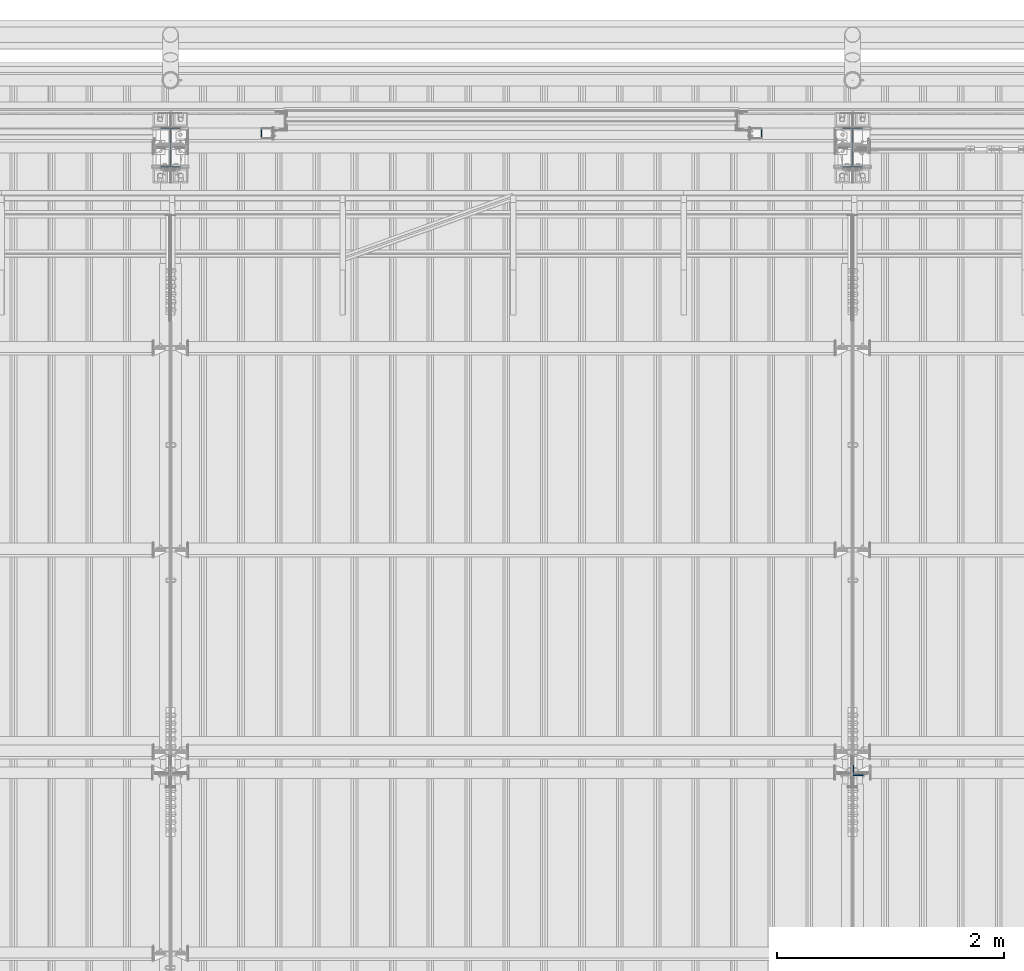
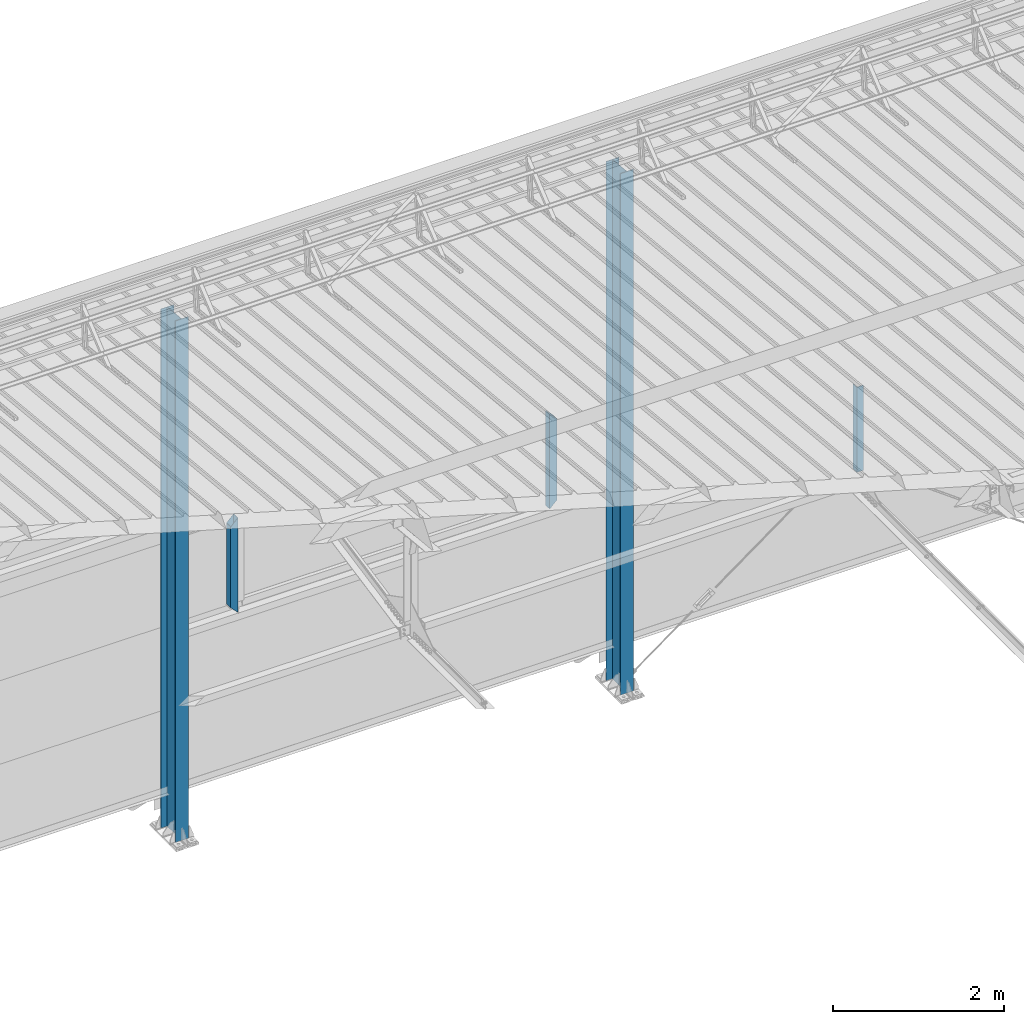
# One storey, part 232 of 709: 5 columns, 5 elements without a shape of their own.
"""IFC4 building model written with IfcOpenShell, lengths in millimetres."""

from ifc_helpers import new_model, si_unit, direction, frame, origin_with_axes, place, context, subcontext, project, spatial, polygons, material, element, aggregate, save


model = new_model("IFC4")

# Units and contexts
model_context = context("Model", 3, precision=0.2, world=origin_with_axes(), true_north=direction((0.0, 1.0)))
body_context = subcontext(model_context, "Body", "Model", "MODEL_VIEW")
ifc_project = project(units=[si_unit("LENGTHUNIT", "METRE", prefix="MILLI"), si_unit("AREAUNIT", "SQUARE_METRE"), si_unit("VOLUMEUNIT", "CUBIC_METRE"), si_unit("MASSUNIT", "GRAM", prefix="KILO"), si_unit("TIMEUNIT", "SECOND"), si_unit("PLANEANGLEUNIT", "RADIAN"), si_unit("SOLIDANGLEUNIT", "STERADIAN"), si_unit("THERMODYNAMICTEMPERATUREUNIT", "DEGREE_CELSIUS"), si_unit("LUMINOUSINTENSITYUNIT", "LUMEN")], contexts=[model_context])

# Site, building, storey
site_placement = place(None, origin_with_axes())
site = spatial("IfcSite", under=ifc_project, at=site_placement, CompositionType="ELEMENT")
building_placement = place(site_placement, origin_with_axes())
building = spatial("IfcBuilding", under=site, at=building_placement, Name="Undefined", CompositionType="ELEMENT")
storey_placement = place(building_placement, origin_with_axes())
storey = spatial("IfcBuildingStorey", under=building, at=storey_placement, Name="Undefined", CompositionType="ELEMENT", Elevation=0.0)

# Assembly, column
assembly_1_placement = place(storey_placement, frame((16000.0, 21827.0, -200.0), z_axis=(-1.0, 0.0, 0.0), x_axis=(0.0, 0.0, 1.0)))
assembly_1 = element("IfcElementAssembly", 1, at=assembly_1_placement, inside=storey)
ifc_material_1 = material(Name="C355-5", Category="STEEL")
column_1_placement = place(assembly_1_placement, origin_with_axes())
column_1 = element("IfcColumn", 2, at=column_1_placement, material=ifc_material_1, ObjectType="413", context=body_context, shape_type="Tessellation", body=[
    polygons([(25.0, -173.0, -87.0), (25.0, -164.0, -87.0), (7454.62297, -164.0, -87.0), (7455.52297, -173.0, -87.0), (25.0, -164.0, -3.0), (7454.62297, -164.0, -3.0), (25.0, 164.0, -3.0), (7421.82297, 164.0, -3.0), (25.0, 164.0, -87.0), (7421.82297, 164.0, -87.0), (25.0, 173.0, -87.0), (7420.92297, 173.0, -87.0), (25.0, 173.0, 87.0), (7420.92297, 173.0, 87.0), (25.0, 164.0, 87.0), (7421.82297, 164.0, 87.0), (25.0, 164.0, 3.0), (7421.82297, 164.0, 3.0), (25.0, -164.0, 3.0), (7454.62297, -164.0, 3.0), (25.0, -164.0, 87.0), (7454.62297, -164.0, 87.0), (25.0, -173.0, 87.0), (7455.52297, -173.0, 87.0)], [[[1, 2, 3, 4]], [[2, 5, 6, 3]], [[5, 7, 8, 6]], [[7, 9, 10, 8]], [[9, 11, 12, 10]], [[11, 13, 14, 12]], [[13, 15, 16, 14]], [[15, 17, 18, 16]], [[17, 19, 20, 18]], [[19, 21, 22, 20]], [[21, 23, 24, 22]], [[23, 1, 4, 24]], [[6, 8, 10, 12, 14, 16, 18, 20, 22, 24, 4, 3]], [[23, 21, 19, 17, 15, 13, 11, 9, 7, 5, 2, 1]]], closed=True),
])
aggregate(assembly_1, [column_1])

assembly_2_placement = place(storey_placement, frame((22051.0, 16347.7, 6024.30002), z_axis=(0.0, 1.0, 0.0), x_axis=(0.0, 0.0, 1.0)))
assembly_2 = element("IfcElementAssembly", 3, at=assembly_2_placement, inside=storey)
ifc_material_2 = material(Name="C345-5", Category="STEEL")
column_2_placement = place(assembly_2_placement, origin_with_axes())
column_2 = element("IfcColumn", 4, at=column_2_placement, material=ifc_material_2, ObjectType="436", context=body_context, shape_type="Tessellation", body=[
    polygons([(185.7, -45.0, -45.0), (185.7, 45.0, -45.0), (1399.4109, 45.0, -45.0), (1399.4109, -45.0, -45.0), (185.7, 45.0, -39.0), (1399.4109, 45.0, -39.0), (185.7, -39.0, -39.0), (1399.4109, -39.0, -39.0), (185.7, -39.0, 45.0), (1399.4109, -39.0, 45.0), (185.7, -45.0, 45.0), (1399.4109, -45.0, 45.0)], [[[1, 2, 3, 4]], [[2, 5, 6, 3]], [[5, 7, 8, 6]], [[7, 9, 10, 8]], [[9, 11, 12, 10]], [[11, 1, 4, 12]], [[6, 8, 10, 12, 4, 3]], [[11, 9, 7, 5, 2, 1]]], closed=True),
])
aggregate(assembly_2, [column_2])

assembly_3_placement = place(storey_placement, frame((22000.0, 21827.0, -200.0), z_axis=(-1.0, 0.0, 0.0), x_axis=(0.0, 0.0, 1.0)))
assembly_3 = element("IfcElementAssembly", 5, at=assembly_3_placement, inside=storey)
column_3_placement = place(assembly_3_placement, origin_with_axes())
column_3 = element("IfcColumn", 6, at=column_3_placement, material=ifc_material_1, ObjectType="413", context=body_context, shape_type="Tessellation", body=[
    polygons([(25.0, -173.0, -87.0), (25.0, -164.0, -87.0), (7454.62297, -164.0, -87.0), (7455.52297, -173.0, -87.0), (25.0, -164.0, -3.0), (7454.62297, -164.0, -3.0), (25.0, 164.0, -3.0), (7421.82297, 164.0, -3.0), (25.0, 164.0, -87.0), (7421.82297, 164.0, -87.0), (25.0, 173.0, -87.0), (7420.92297, 173.0, -87.0), (25.0, 173.0, 87.0), (7420.92297, 173.0, 87.0), (25.0, 164.0, 87.0), (7421.82297, 164.0, 87.0), (25.0, 164.0, 3.0), (7421.82297, 164.0, 3.0), (25.0, -164.0, 3.0), (7454.62297, -164.0, 3.0), (25.0, -164.0, 87.0), (7454.62297, -164.0, 87.0), (25.0, -173.0, 87.0), (7455.52297, -173.0, 87.0)], [[[1, 2, 3, 4]], [[2, 5, 6, 3]], [[5, 7, 8, 6]], [[7, 9, 10, 8]], [[9, 11, 12, 10]], [[11, 13, 14, 12]], [[13, 15, 16, 14]], [[15, 17, 18, 16]], [[17, 19, 20, 18]], [[19, 21, 22, 20]], [[21, 23, 24, 22]], [[23, 1, 4, 24]], [[6, 8, 10, 12, 14, 16, 18, 20, 22, 24, 4, 3]], [[23, 21, 19, 17, 15, 13, 11, 9, 7, 5, 2, 1]]], closed=True),
])
aggregate(assembly_3, [column_3])

assembly_4_placement = place(storey_placement, frame((21150.0, 21950.0, 2600.0), z_axis=(-1.0, 0.0, 0.0), x_axis=(0.0, 0.0, 1.0)))
assembly_4 = element("IfcElementAssembly", 7, at=assembly_4_placement, inside=storey)
ifc_material_3 = material(Name="C355", Category="STEEL")
column_4_placement = place(assembly_4_placement, origin_with_axes())
column_4 = element("IfcColumn", 8, at=column_4_placement, material=ifc_material_3, ObjectType="493", context=body_context, shape_type="Tessellation", body=[
    polygons([(10.0, -50.0, 50.0), (110.0, -50.0, -50.0), (1260.0, -50.0, -50.0), (1360.0, -50.0, 50.0), (10.0, 50.0, 50.0), (1360.0, 50.0, 50.0), (110.0, 50.0, -50.0), (1260.0, 50.0, -50.0), (13.0, -47.0, 47.0), (13.0, 47.0, 47.0), (1357.0, 47.0, 47.0), (1357.0, -47.0, 47.0), (107.0, -47.0, -47.0), (1263.0, -47.0, -47.0), (107.0, 47.0, -47.0), (1263.0, 47.0, -47.0)], [[[1, 2, 3, 4]], [[5, 1, 4, 6]], [[7, 5, 6, 8]], [[2, 7, 8, 3]], [[1, 5, 7, 2], [9, 13, 15, 10]], [[9, 10, 11, 12]], [[13, 9, 12, 14]], [[15, 13, 14, 16]], [[10, 15, 16, 11]], [[3, 8, 6, 4], [14, 12, 11, 16]]], closed=True),
])
aggregate(assembly_4, [column_4])

assembly_5_placement = place(storey_placement, frame((16850.0, 21950.0, 2600.0), z_axis=(-1.0, 0.0, 0.0), x_axis=(0.0, 0.0, 1.0)))
assembly_5 = element("IfcElementAssembly", 9, at=assembly_5_placement, inside=storey)
column_5_placement = place(assembly_5_placement, origin_with_axes())
column_5 = element("IfcColumn", 10, at=column_5_placement, material=ifc_material_3, ObjectType="493", context=body_context, shape_type="Tessellation", body=[
    polygons([(10.0, -50.0, -50.0), (10.0, 50.0, -50.0), (1360.0, 50.0, -50.0), (1360.0, -50.0, -50.0), (110.0, -50.0, 50.0), (1260.0, -50.0, 50.0), (110.0, 50.0, 50.0), (1260.0, 50.0, 50.0), (107.0, 47.0, 47.0), (13.0, 47.0, -47.0), (1357.0, 47.0, -47.0), (1263.0, 47.0, 47.0), (107.0, -47.0, 47.0), (1263.0, -47.0, 47.0), (13.0, -47.0, -47.0), (1357.0, -47.0, -47.0)], [[[1, 2, 3, 4]], [[5, 1, 4, 6]], [[7, 5, 6, 8]], [[2, 7, 8, 3]], [[1, 5, 7, 2], [15, 10, 9, 13]], [[9, 10, 11, 12]], [[13, 9, 12, 14]], [[15, 13, 14, 16]], [[10, 15, 16, 11]], [[6, 4, 3, 8], [14, 12, 11, 16]]], closed=True),
])
aggregate(assembly_5, [column_5])

save(model, "model.ifc")
